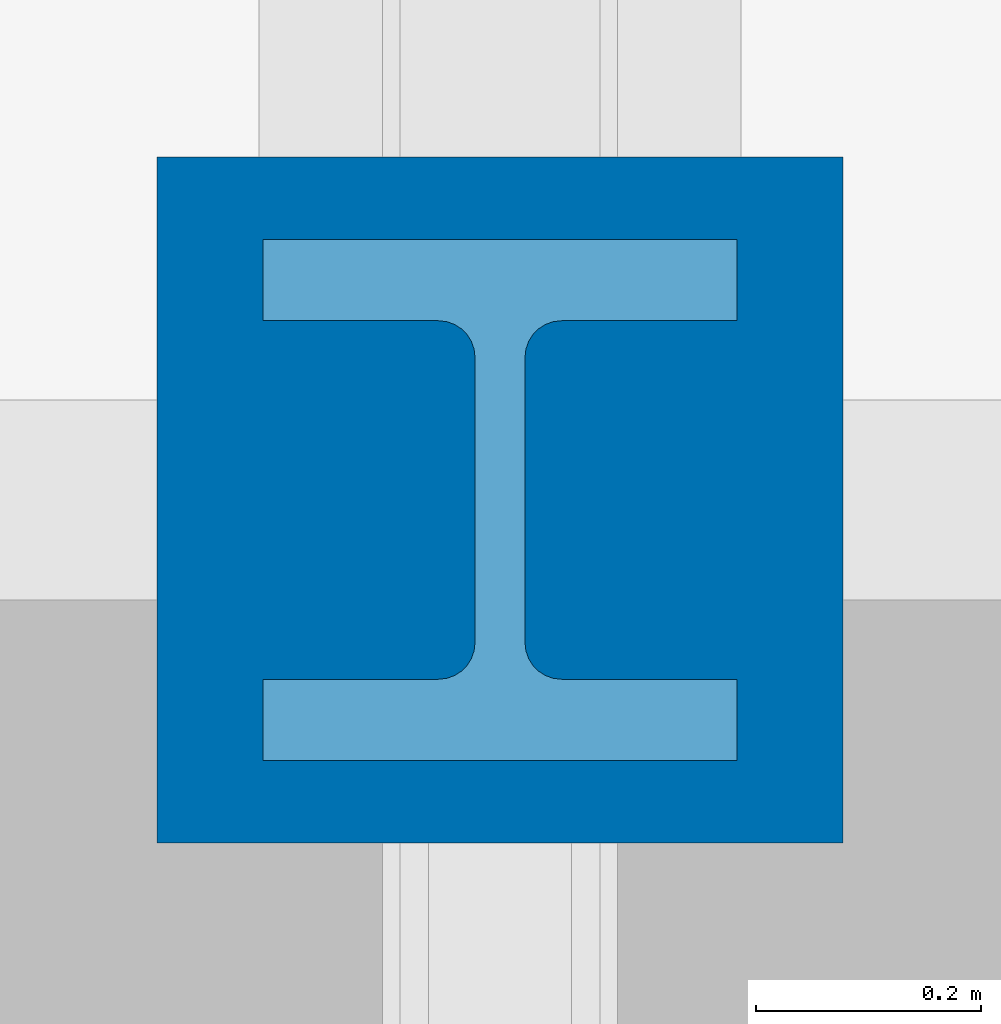
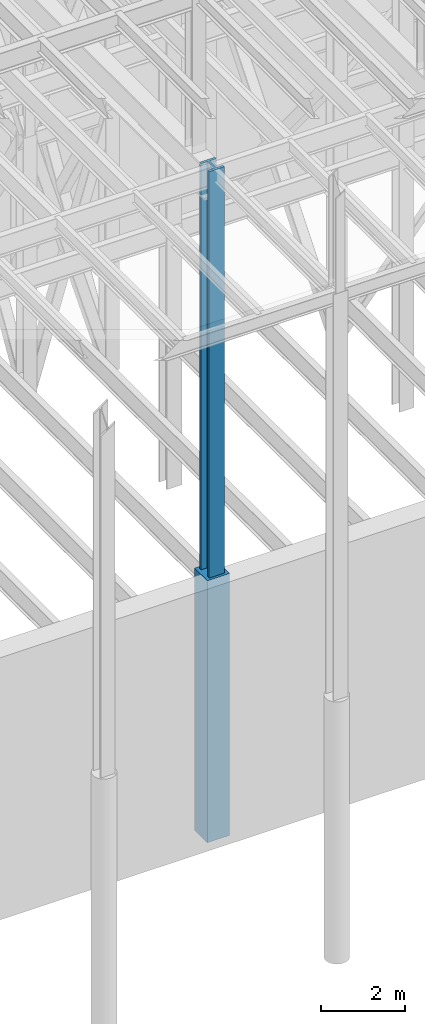
# One storey, part 77 of 150: 2 columns.
"""IFC2X3 building model written with IfcOpenShell, lengths in millimetres."""

from ifc_helpers import new_model, si_unit, frame, origin_with_axes, origin_2d_with_axis, place, context, subcontext, project, spatial, rectangle, i_section, extrude, material, type_object, element, save


model = new_model("IFC2X3")

# Units and contexts
model_context = context("Model", 3, precision=1e-05, world=origin_with_axes())
body_context = subcontext(model_context, "Body", "Model", "MODEL_VIEW")
ifc_project = project(units=[si_unit("LENGTHUNIT", "METRE", prefix="MILLI"), si_unit("AREAUNIT", "SQUARE_METRE"), si_unit("VOLUMEUNIT", "CUBIC_METRE"), si_unit("MASSUNIT", "GRAM", prefix="KILO"), si_unit("TIMEUNIT", "SECOND"), si_unit("PLANEANGLEUNIT", "RADIAN"), si_unit("SOLIDANGLEUNIT", "STERADIAN"), si_unit("THERMODYNAMICTEMPERATUREUNIT", "DEGREE_CELSIUS"), si_unit("LUMINOUSINTENSITYUNIT", "LUMEN")], contexts=[model_context])

# Site, building, storey
site_placement = place(None, origin_with_axes())
site = spatial("IfcSite", under=ifc_project, at=site_placement, CompositionType="ELEMENT")
building_placement = place(site_placement, origin_with_axes())
building = spatial("IfcBuilding", under=site, at=building_placement, Name="Undefined", CompositionType="ELEMENT")
storey_placement = place(building_placement, origin_with_axes())
storey = spatial("IfcBuildingStorey", under=building, at=storey_placement, Name="Undefined", CompositionType="ELEMENT", Elevation=0.0)

# Columns
ifc_material_1 = material(Name="CONCRETE/5000")
column_type_1 = type_object("IfcColumnType", PredefinedType="NOTDEFINED")
column_1_placement = place(storey_placement, frame((69392.8, 9398.0, 16154.4), z_axis=(0.0, 0.0, 1.0), x_axis=(1.0, 0.0, 0.0)))
element("IfcColumn", 1, at=column_1_placement, inside=storey, type_object=column_type_1, material=ifc_material_1, Name="COLUMN", context=body_context, shape_type="SweptSolid", body=[
    extrude(rectangle(XDim=609.6, YDim=609.6, at=origin_2d_with_axis()), frame((0.0, 0.0, 7620.0), z_axis=(0.0, 0.0, -1.0), x_axis=(0.0, -1.0, 0.0)), (0.0, 0.0, 1.0), 7620.0),
])
ifc_material_2 = material(Name="STEEL/A992")
column_type_2 = type_object("IfcColumnType", Name="W14X398", PredefinedType="NOTDEFINED")
column_2_placement = place(storey_placement, frame((69392.8, 9398.0, 22707.6), z_axis=(0.0, 0.0, 1.0), x_axis=(1.0, 0.0, 0.0)))
element("IfcColumn", 2, at=column_2_placement, inside=storey, type_object=column_type_2, material=ifc_material_2, Name="COLUMN", ObjectType="W14X398", context=body_context, shape_type="SweptSolid", body=[
    extrude(i_section(OverallWidth=421.64, OverallDepth=463.55, WebThickness=44.45, FlangeThickness=72.39, FilletRadius=32.512, at=origin_2d_with_axis()), frame((0.0, 0.0, 12877.8), z_axis=(0.0, 0.0, -1.0), x_axis=(-1.0, 0.0, 0.0)), (0.0, 0.0, 1.0), 12877.8),
])

save(model, "model.ifc")
